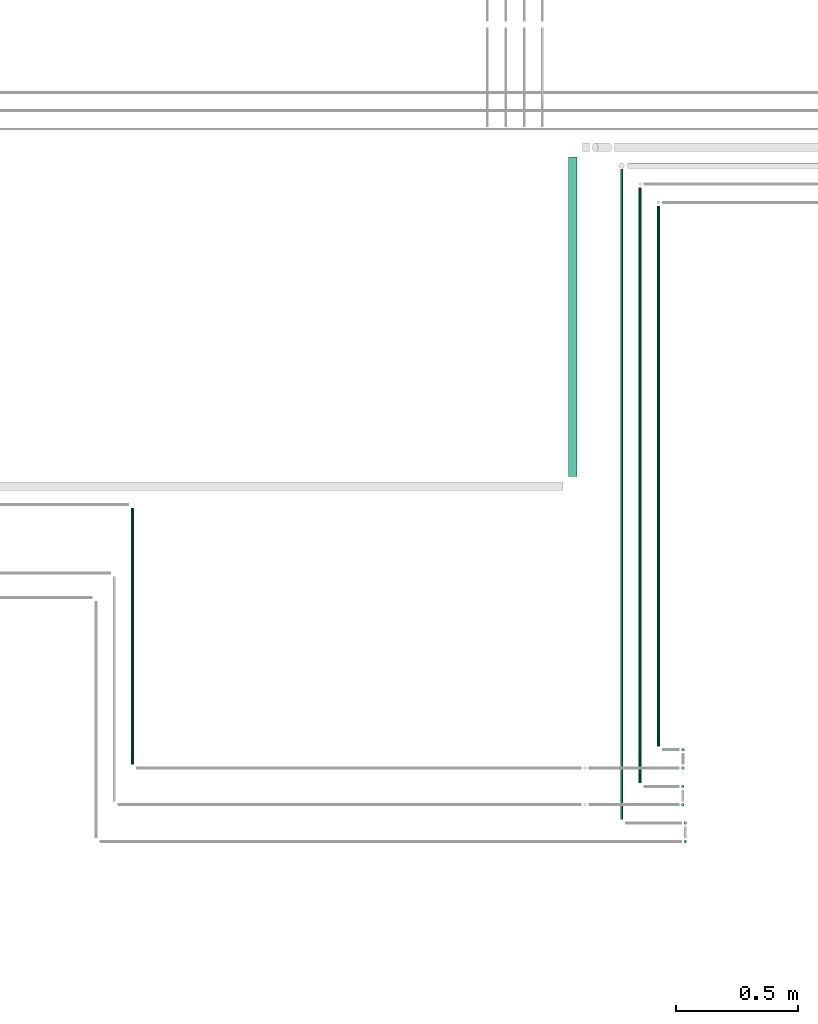
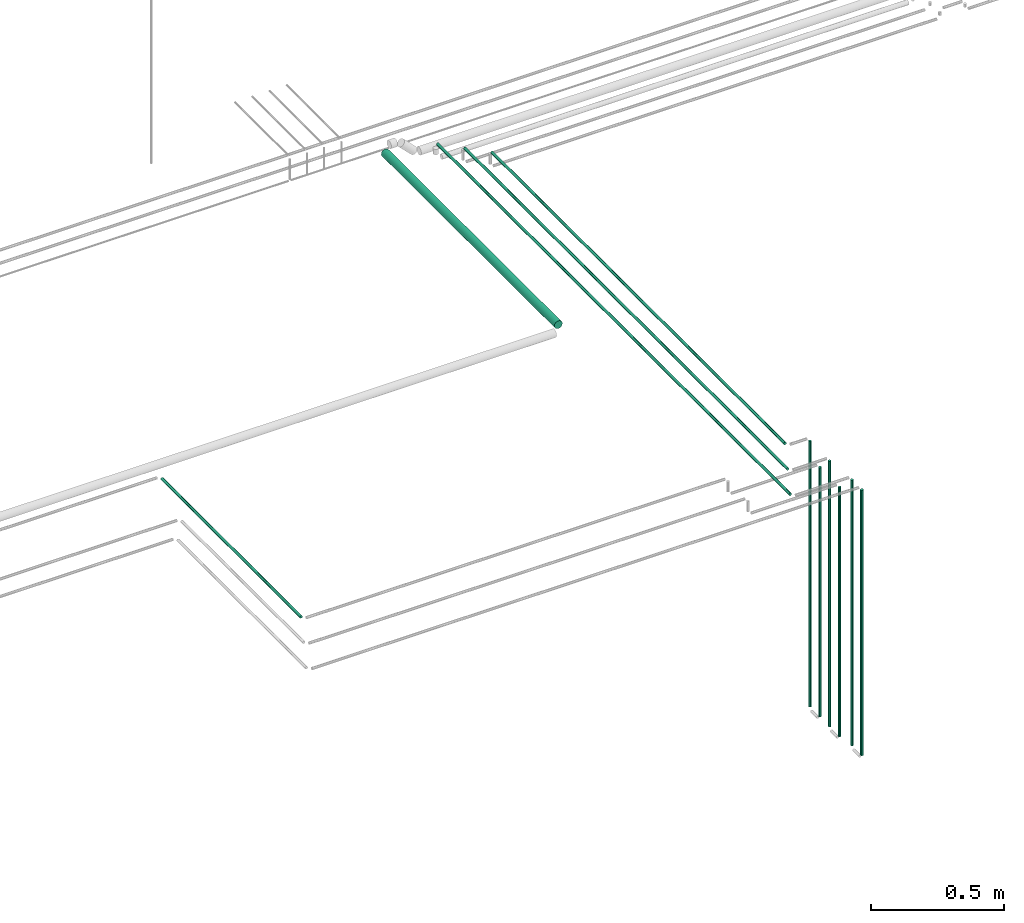
# One storey, part 24 of 331: 11 flow segments.
"""IFC2X3 building model written with IfcOpenShell, lengths in millimetres."""

from ifc_helpers import new_model, entity, si_unit, converted_unit, derived_unit, direction, frame, frame_2d, origin, origin_2d_with_axis, place, context, subcontext, project, spatial, circle, extrude, type_object, element, save


model = new_model("IFC2X3")

# Units and contexts
model_context = context("Model", 3, precision=0.01, world=origin(), true_north=direction((6.12303176911189e-17, 1.0)))
body_context = subcontext(model_context, "Body", "Model", "MODEL_VIEW")
ifc_project = project(units=[si_unit("LENGTHUNIT", "METRE", prefix="MILLI"), si_unit("AREAUNIT", "SQUARE_METRE"), si_unit("VOLUMEUNIT", "CUBIC_METRE"), converted_unit("PLANEANGLEUNIT", "DEGREE", entity("IfcRatioMeasure", 0.0174532925199433), si_unit("PLANEANGLEUNIT", "RADIAN"), dimensions=[0, 0, 0, 0, 0, 0, 0]), si_unit("MASSUNIT", "GRAM", prefix="KILO"), derived_unit("MASSDENSITYUNIT", [(si_unit("MASSUNIT", "GRAM", prefix="KILO"), 1), (si_unit("LENGTHUNIT", "METRE"), -3)]), derived_unit("MOMENTOFINERTIAUNIT", [(si_unit("LENGTHUNIT", "METRE"), 4)]), si_unit("TIMEUNIT", "SECOND"), si_unit("FREQUENCYUNIT", "HERTZ"), si_unit("THERMODYNAMICTEMPERATUREUNIT", "DEGREE_CELSIUS"), derived_unit("THERMALTRANSMITTANCEUNIT", [(si_unit("MASSUNIT", "GRAM", prefix="KILO"), 1), (si_unit("THERMODYNAMICTEMPERATUREUNIT", "KELVIN"), -1), (si_unit("TIMEUNIT", "SECOND"), -3)]), derived_unit("VOLUMETRICFLOWRATEUNIT", [(si_unit("LENGTHUNIT", "METRE"), 3), (si_unit("TIMEUNIT", "SECOND"), -1)]), derived_unit("MASSFLOWRATEUNIT", [(si_unit("MASSUNIT", "GRAM", prefix="KILO"), 1), (si_unit("TIMEUNIT", "SECOND"), -1)]), derived_unit("ROTATIONALFREQUENCYUNIT", [(si_unit("TIMEUNIT", "SECOND"), -1)]), si_unit("ELECTRICCURRENTUNIT", "AMPERE"), si_unit("ELECTRICVOLTAGEUNIT", "VOLT"), si_unit("POWERUNIT", "WATT"), si_unit("FORCEUNIT", "NEWTON", prefix="KILO"), si_unit("ILLUMINANCEUNIT", "LUX"), si_unit("LUMINOUSFLUXUNIT", "LUMEN"), si_unit("LUMINOUSINTENSITYUNIT", "CANDELA"), derived_unit("USERDEFINED", [(si_unit("MASSUNIT", "GRAM", prefix="KILO"), -1), (si_unit("LENGTHUNIT", "METRE"), -2), (si_unit("TIMEUNIT", "SECOND"), 3), (si_unit("LUMINOUSFLUXUNIT", "LUMEN"), 1)]), derived_unit("LINEARVELOCITYUNIT", [(si_unit("LENGTHUNIT", "METRE"), 1), (si_unit("TIMEUNIT", "SECOND"), -1)]), si_unit("PRESSUREUNIT", "PASCAL"), derived_unit("USERDEFINED", [(si_unit("LENGTHUNIT", "METRE"), -2), (si_unit("MASSUNIT", "GRAM", prefix="KILO"), 1), (si_unit("TIMEUNIT", "SECOND"), -2)]), derived_unit("LINEARFORCEUNIT", [(si_unit("MASSUNIT", "GRAM", prefix="KILO"), 1), (si_unit("LENGTHUNIT", "METRE"), 1), (si_unit("TIMEUNIT", "SECOND"), -2), (si_unit("LENGTHUNIT", "METRE"), -1)]), derived_unit("PLANARFORCEUNIT", [(si_unit("MASSUNIT", "GRAM", prefix="KILO"), 1), (si_unit("LENGTHUNIT", "METRE"), 1), (si_unit("TIMEUNIT", "SECOND"), -2), (si_unit("LENGTHUNIT", "METRE"), -2)])], contexts=[model_context])

# Site, building, storey
site_placement = place(None, frame((0.0, -0.00077364408347762, 0.0)))
site = spatial("IfcSite", under=ifc_project, at=site_placement, CompositionType="ELEMENT")
building_placement = place(site_placement, origin())
building = spatial("IfcBuilding", under=site, at=building_placement, CompositionType="ELEMENT")
storey_placement = place(building_placement, origin())
storey = spatial("IfcBuildingStorey", under=building, at=storey_placement, CompositionType="ELEMENT", Elevation=0.0)

# Flow segments
pipe_segment_type = type_object("IfcPipeSegmentType", PredefinedType="NOTDEFINED")
flow_segment_1_placement = place(building_placement, frame((34737.3375919762, 13376.4652958905, 6742.40472776408)))
element("IfcFlowSegment", 1, at=flow_segment_1_placement, inside=storey, type_object=pipe_segment_type, context=body_context, shape_type="SweptSolid", body=[
    extrude(circle(Radius=6.0, at=frame_2d((0.0, -1.08286712929839e-12), x_axis=(1.0, 0.0))), frame((7.59527223591454, 0.0, 7.5952722359167), z_axis=(0.0, 1.0, 0.0), x_axis=(-1.0, 0.0, 0.0)), (0.0, 0.0, 1.0), 2209.51937431252),
])
flow_segment_2_placement = place(building_placement, frame((34662.3375919762, 13226.4652958905, 6742.40472776408)))
element("IfcFlowSegment", 2, at=flow_segment_2_placement, inside=storey, type_object=pipe_segment_type, context=body_context, shape_type="SweptSolid", body=[
    extrude(circle(Radius=6.0, at=frame_2d((0.0, -1.08286712929839e-12), x_axis=(1.0, 0.0))), frame((7.59527223591454, 0.0, 7.5952722359167), z_axis=(0.0, 1.0, 0.0), x_axis=(-1.0, 0.0, 0.0)), (0.0, 0.0, 1.0), 2434.51937431242),
])
flow_segment_3_placement = place(building_placement, frame((34587.3375919762, 13076.4652958905, 6742.40472776408)))
element("IfcFlowSegment", 3, at=flow_segment_3_placement, inside=storey, type_object=pipe_segment_type, context=body_context, shape_type="SweptSolid", body=[
    extrude(circle(Radius=6.0, at=frame_2d((0.0, -1.08286712929839e-12), x_axis=(1.0, 0.0))), frame((7.59527223591454, 0.0, 7.5952722359167), z_axis=(0.0, 1.0, 0.0), x_axis=(-1.0, 0.0, 0.0)), (0.0, 0.0, 1.0), 2659.51937431243),
])
flow_segment_4_placement = place(building_placement, frame((34846.9512077447, 13054.8700236546, 5514.0)))
element("IfcFlowSegment", 4, at=flow_segment_4_placement, inside=storey, type_object=pipe_segment_type, context=body_context, shape_type="SweptSolid", body=[
    extrude(circle(Radius=6.0, at=frame_2d((0.0, -2.16573425859679e-12), x_axis=(1.0, 0.0))), frame((7.59527223591454, 7.59527223591887, 0.0)), (0.0, 0.0, 1.0), 1222.00000000001),
])
for number, where in (
    (5, (34836.7603220303, 13204.8700236546, 5514.0)),
    (6, (34837.3375919762, 13354.8700236546, 5514.0)),
):
    element("IfcFlowSegment", number, at=place(building_placement, frame(where)), inside=storey, type_object=pipe_segment_type, context=body_context, shape_type="SweptSolid", body=[
        extrude(circle(Radius=6.0, at=origin_2d_with_axis()), frame((7.59527223591454, 7.5952722359167, 0.0)), (0.0, 0.0, 1.0), 1222.00000000001),
    ])
flow_segment_5_placement = place(building_placement, frame((34846.9512077447, 12979.8700236546, 5514.0)))
element("IfcFlowSegment", 7, at=flow_segment_5_placement, inside=storey, type_object=pipe_segment_type, context=body_context, shape_type="SweptSolid", body=[
    extrude(circle(Radius=6.0, at=frame_2d((0.0, -2.16573425859679e-12), x_axis=(1.0, 0.0))), frame((7.59527223591454, 7.59527223591454, 0.0), z_axis=(0.0, 0.0, 1.0), x_axis=(-1.0, 0.0, 0.0)), (0.0, 0.0, 1.0), 1222.0),
])
flow_segment_6_placement = place(storey_placement, frame((34836.7603220303, 13129.8700236546, 5514.0)))
element("IfcFlowSegment", 8, at=flow_segment_6_placement, inside=storey, type_object=pipe_segment_type, context=body_context, shape_type="SweptSolid", body=[
    extrude(circle(Radius=6.0, at=origin_2d_with_axis()), frame((7.59527223591454, 7.5952722359167, 0.0), z_axis=(0.0, 0.0, 1.0), x_axis=(-1.0, 0.0, 0.0)), (0.0, 0.0, 1.0), 1147.00000000001),
])
flow_segment_7_placement = place(storey_placement, frame((34837.3375919762, 13279.8700236546, 5514.0)))
element("IfcFlowSegment", 9, at=flow_segment_7_placement, inside=storey, type_object=pipe_segment_type, context=body_context, shape_type="SweptSolid", body=[
    extrude(circle(Radius=6.0, at=frame_2d((0.0, -2.16573425859679e-12), x_axis=(1.0, 0.0))), frame((7.59527223591454, 7.59527223591454, 0.0), z_axis=(0.0, 0.0, 1.0), x_axis=(-1.0, 0.0, 0.0)), (0.0, 0.0, 1.0), 1147.00000000001),
])
flow_segment_8_placement = place(building_placement, frame((32587.4056432914, 13301.4652958905, 6742.40472776408)))
element("IfcFlowSegment", 10, at=flow_segment_8_placement, inside=storey, type_object=pipe_segment_type, context=body_context, shape_type="SweptSolid", body=[
    extrude(circle(Radius=6.0, at=origin_2d_with_axis()), frame((7.59527223591454, 0.0, 7.59527223591562), z_axis=(0.0, 1.0, 0.0), x_axis=(1.0, 0.0, 0.0)), (0.0, 0.0, 1.0), 1049.53437451966),
])
flow_segment_9_placement = place(building_placement, frame((34375.9023107718, 14479.9996704102, 6730.90472776408)))
element("IfcFlowSegment", 11, at=flow_segment_9_placement, inside=storey, type_object=pipe_segment_type, context=body_context, shape_type="SweptSolid", body=[
    extrude(circle(Radius=17.5, at=frame_2d((1.73258740687743e-11, 0.0), x_axis=(1.0, 0.0))), frame((19.0952722359336, 0.0, 19.0952722359163), z_axis=(0.0, 1.0, 0.0), x_axis=(-1.0, 0.0, 0.0)), (0.0, 0.0, 1.0), 1304.98499979277),
])

save(model, "model.ifc")
